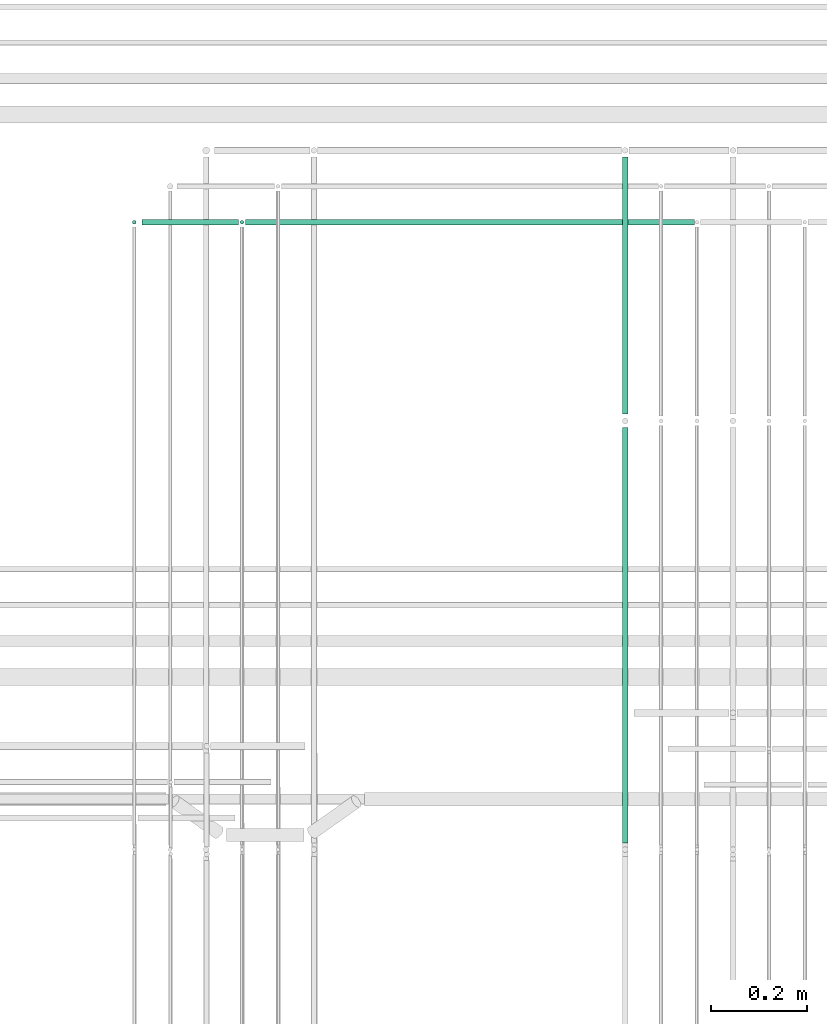
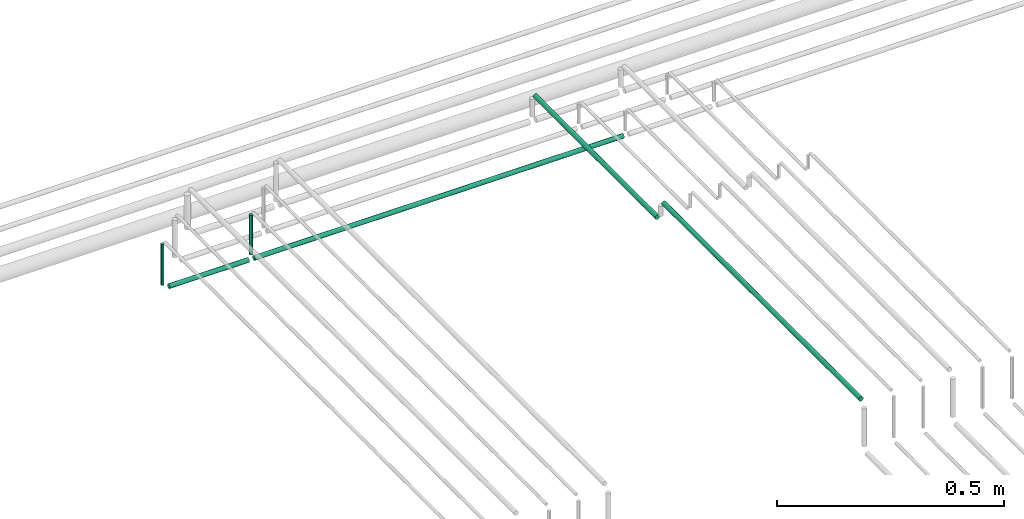
# One storey, part 188 of 331: 6 flow segments.
"""IFC2X3 building model written with IfcOpenShell, lengths in millimetres."""

from ifc_helpers import new_model, entity, si_unit, converted_unit, derived_unit, direction, frame, frame_2d, origin, origin_2d_with_axis, place, context, subcontext, project, spatial, circle, extrude, type_object, element, save


model = new_model("IFC2X3")

# Units and contexts
model_context = context("Model", 3, precision=0.01, world=origin(), true_north=direction((6.12303176911189e-17, 1.0)))
body_context = subcontext(model_context, "Body", "Model", "MODEL_VIEW")
ifc_project = project(units=[si_unit("LENGTHUNIT", "METRE", prefix="MILLI"), si_unit("AREAUNIT", "SQUARE_METRE"), si_unit("VOLUMEUNIT", "CUBIC_METRE"), converted_unit("PLANEANGLEUNIT", "DEGREE", entity("IfcRatioMeasure", 0.0174532925199433), si_unit("PLANEANGLEUNIT", "RADIAN"), dimensions=[0, 0, 0, 0, 0, 0, 0]), si_unit("MASSUNIT", "GRAM", prefix="KILO"), derived_unit("MASSDENSITYUNIT", [(si_unit("MASSUNIT", "GRAM", prefix="KILO"), 1), (si_unit("LENGTHUNIT", "METRE"), -3)]), derived_unit("MOMENTOFINERTIAUNIT", [(si_unit("LENGTHUNIT", "METRE"), 4)]), si_unit("TIMEUNIT", "SECOND"), si_unit("FREQUENCYUNIT", "HERTZ"), si_unit("THERMODYNAMICTEMPERATUREUNIT", "DEGREE_CELSIUS"), derived_unit("THERMALTRANSMITTANCEUNIT", [(si_unit("MASSUNIT", "GRAM", prefix="KILO"), 1), (si_unit("THERMODYNAMICTEMPERATUREUNIT", "KELVIN"), -1), (si_unit("TIMEUNIT", "SECOND"), -3)]), derived_unit("VOLUMETRICFLOWRATEUNIT", [(si_unit("LENGTHUNIT", "METRE"), 3), (si_unit("TIMEUNIT", "SECOND"), -1)]), derived_unit("MASSFLOWRATEUNIT", [(si_unit("MASSUNIT", "GRAM", prefix="KILO"), 1), (si_unit("TIMEUNIT", "SECOND"), -1)]), derived_unit("ROTATIONALFREQUENCYUNIT", [(si_unit("TIMEUNIT", "SECOND"), -1)]), si_unit("ELECTRICCURRENTUNIT", "AMPERE"), si_unit("ELECTRICVOLTAGEUNIT", "VOLT"), si_unit("POWERUNIT", "WATT"), si_unit("FORCEUNIT", "NEWTON", prefix="KILO"), si_unit("ILLUMINANCEUNIT", "LUX"), si_unit("LUMINOUSFLUXUNIT", "LUMEN"), si_unit("LUMINOUSINTENSITYUNIT", "CANDELA"), derived_unit("USERDEFINED", [(si_unit("MASSUNIT", "GRAM", prefix="KILO"), -1), (si_unit("LENGTHUNIT", "METRE"), -2), (si_unit("TIMEUNIT", "SECOND"), 3), (si_unit("LUMINOUSFLUXUNIT", "LUMEN"), 1)]), derived_unit("LINEARVELOCITYUNIT", [(si_unit("LENGTHUNIT", "METRE"), 1), (si_unit("TIMEUNIT", "SECOND"), -1)]), si_unit("PRESSUREUNIT", "PASCAL"), derived_unit("USERDEFINED", [(si_unit("LENGTHUNIT", "METRE"), -2), (si_unit("MASSUNIT", "GRAM", prefix="KILO"), 1), (si_unit("TIMEUNIT", "SECOND"), -2)]), derived_unit("LINEARFORCEUNIT", [(si_unit("MASSUNIT", "GRAM", prefix="KILO"), 1), (si_unit("LENGTHUNIT", "METRE"), 1), (si_unit("TIMEUNIT", "SECOND"), -2), (si_unit("LENGTHUNIT", "METRE"), -1)]), derived_unit("PLANARFORCEUNIT", [(si_unit("MASSUNIT", "GRAM", prefix="KILO"), 1), (si_unit("LENGTHUNIT", "METRE"), 1), (si_unit("TIMEUNIT", "SECOND"), -2), (si_unit("LENGTHUNIT", "METRE"), -2)])], contexts=[model_context])

# Site, building, storey
site_placement = place(None, frame((0.0, -0.00077364408347762, 0.0)))
site = spatial("IfcSite", under=ifc_project, at=site_placement, CompositionType="ELEMENT")
building_placement = place(site_placement, origin())
building = spatial("IfcBuilding", under=site, at=building_placement, CompositionType="ELEMENT")
storey_placement = place(building_placement, origin())
storey = spatial("IfcBuildingStorey", under=building, at=storey_placement, CompositionType="ELEMENT", Elevation=0.0)

# Flow segments
pipe_segment_type = type_object("IfcPipeSegmentType", PredefinedType="NOTDEFINED")
flow_segment_1_placement = place(storey_placement, frame((43702.0420767625, 9392.40472776387, 18442.4047277641)))
element("IfcFlowSegment", 1, at=flow_segment_1_placement, inside=storey, type_object=pipe_segment_type, context=body_context, shape_type="SweptSolid", body=[
    extrude(circle(Radius=6.0, at=frame_2d((0.0, -2.16573425859679e-12), x_axis=(1.0, 0.0))), frame((0.0, 7.59527223607263, 7.59527223591454), z_axis=(1.0, 0.0, 0.0), x_axis=(0.0, -1.0, 0.0)), (0.0, 0.0, 1.0), 937.286850831168),
])
flow_segment_2_placement = place(storey_placement, frame((43464.4468045266, 9394.40472776402, 18460.0)))
element("IfcFlowSegment", 2, at=flow_segment_2_placement, inside=storey, type_object=pipe_segment_type, context=body_context, shape_type="SweptSolid", body=[
    extrude(circle(Radius=4.0, at=origin_2d_with_axis()), frame((5.59527223591499, 5.59527223591607, 0.0), z_axis=(0.0, 0.0, 1.0), x_axis=(-1.0, 0.0, 0.0)), (0.0, 0.0, 1.0), 110.000000000014),
])
flow_segment_3_placement = place(building_placement, frame((43689.4468045266, 9394.40472776402, 18463.0)))
element("IfcFlowSegment", 3, at=flow_segment_3_placement, inside=storey, type_object=pipe_segment_type, context=body_context, shape_type="SweptSolid", body=[
    extrude(circle(Radius=4.0, at=origin_2d_with_axis()), frame((5.59527223591499, 5.59527223591607, 0.0), z_axis=(0.0, 0.0, 1.0), x_axis=(-1.0, 0.0, 0.0)), (0.0, 0.0, 1.0), 107.000000000036),
])
flow_segment_4_placement = place(storey_placement, frame((43486.0420767625, 9392.40472776402, 18442.4047277641)))
element("IfcFlowSegment", 4, at=flow_segment_4_placement, inside=storey, type_object=pipe_segment_type, context=body_context, shape_type="SweptSolid", body=[
    extrude(circle(Radius=6.0, at=frame_2d((0.0, -2.16573425859679e-12), x_axis=(1.0, 0.0))), frame((0.0, 7.59527223591562, 7.59527223591454), z_axis=(1.0, 0.0, 0.0), x_axis=(0.0, -1.0, 0.0)), (0.0, 0.0, 1.0), 202.000000000015),
])
flow_segment_5_placement = place(storey_placement, frame((44487.5706481368, 8104.14880665494, 18572.4047277641)))
element("IfcFlowSegment", 5, at=flow_segment_5_placement, inside=storey, type_object=pipe_segment_type, context=body_context, shape_type="SweptSolid", body=[
    extrude(circle(Radius=6.0, at=frame_2d((0.0, 2.16573425859679e-12), x_axis=(1.0, 0.0))), frame((7.5952722359232, 0.0, 7.59527223591887), z_axis=(0.0, 1.0, 0.0), x_axis=(1.0, 0.0, 0.0)), (0.0, 0.0, 1.0), 867.000000000012),
])
flow_segment_6_placement = place(storey_placement, frame((44487.5706481368, 8999.14880665494, 18517.4047277642)))
element("IfcFlowSegment", 6, at=flow_segment_6_placement, inside=storey, type_object=pipe_segment_type, context=body_context, shape_type="SweptSolid", body=[
    extrude(circle(Radius=6.0, at=frame_2d((0.0, 2.16573425859679e-12), x_axis=(1.0, 0.0))), frame((7.59527223591454, 0.0, 7.59527223591454), z_axis=(0.0, 1.0, 0.0), x_axis=(-1.0, 0.0, 0.0)), (0.0, 0.0, 1.0), 536.851193345028),
])

save(model, "model.ifc")
